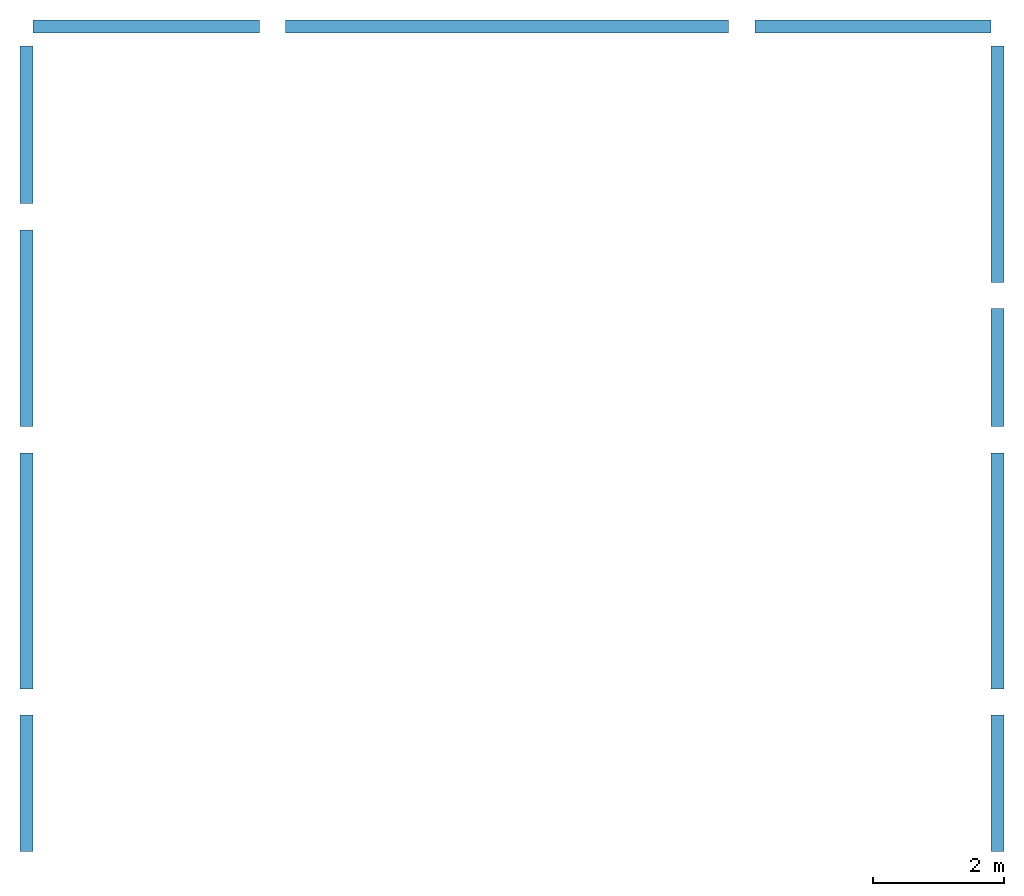
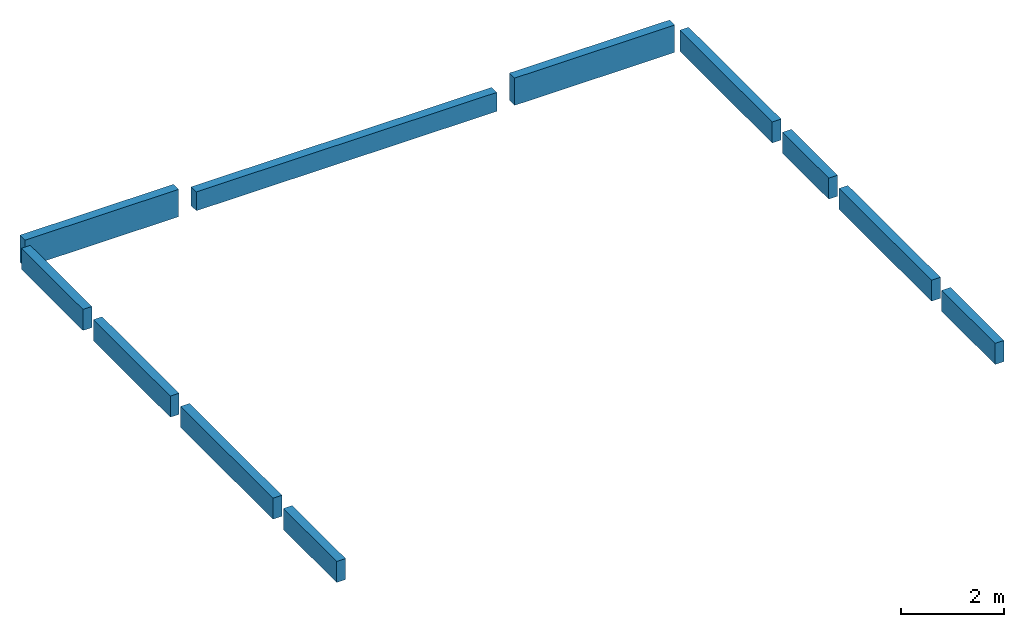
# One storey: 11 walls.
"""IFC4 building model written with IfcOpenShell, lengths in metres."""

from ifc_helpers import new_model, entity, si_unit, converted_unit, frame, origin_with_axes, origin_2d_with_axis, place, context, subcontext, project, spatial, indexed_curve, outline, extrude, material, layer, layer_set, layer_usage, type_object, element, save


model = new_model("IFC4")

# Units and contexts
model_context = context("Model", 3, precision=1e-05, world=origin_with_axes())
plan_context = context("Plan", 2, precision=1e-05, world=origin_2d_with_axis())
body_context = subcontext(model_context, "Body", "Model", "MODEL_VIEW")
ifc_project = project(units=[si_unit("VOLUMEUNIT", "CUBIC_METRE"), si_unit("LENGTHUNIT", "METRE"), converted_unit("PLANEANGLEUNIT", "degree", entity("IfcReal", 0.0174532925199433), si_unit("PLANEANGLEUNIT", "RADIAN"), dimensions=[0, 0, 0, 0, 0, 0, 0]), si_unit("AREAUNIT", "SQUARE_METRE")], contexts=[model_context, plan_context])

# Site, building, storey
site_placement = place(None, origin_with_axes())
site = spatial("IfcSite", under=ifc_project, at=site_placement)
building_placement = place(site_placement, origin_with_axes())
building = spatial("IfcBuilding", under=site, at=building_placement, Name="Building")
storey_placement = place(building_placement, frame((0.0, 0.0, 3.65000009536743), z_axis=(0.0, 0.0, 1.0), x_axis=(1.0, 0.0, 0.0)))
storey = spatial("IfcBuildingStorey", under=building, at=storey_placement, Name="2-Roof1")

# Walls
ifc_material = material(Name="BLK-200", Category="masonry")
ifc_layer = layer(ifc_material, 0.200000002980232)
ifc_layer_set = layer_set([ifc_layer])
ifc_layer_usage_1 = layer_usage(ifc_layer_set, "AXIS2", "POSITIVE", 0.0)
wall_type = type_object("IfcWallType", Name="WAL-01", PredefinedType="STANDARD", material=ifc_layer_set)
wall_1_placement = place(storey_placement, frame((39.5796699523926, 24.8144187927246, -0.150000572204592), z_axis=(0.0, 0.0, 1.0), x_axis=(-0.999999999999989, 1.50995802528085e-07, 0.0)))
element("IfcWall", 1, at=wall_1_placement, inside=storey, type_object=wall_type, material=ifc_layer_usage_1, Name="Wall", context=body_context, shape_type="SweptSolid", body=[
    extrude(outline(indexed_curve([(0.0, 0.0), (0.0, 0.200000002980232), (3.44997030604756, 0.200000002980232), (3.44997030604756, 0.0), (0.0, 0.0)], self_intersect=False)), origin_with_axes(), (0.0, 0.0, 1.0), 0.649999976158142),
])
ifc_layer_usage_2 = layer_usage(ifc_layer_set, "AXIS2", "POSITIVE", 0.0)
wall_2_placement = place(storey_placement, frame((50.7346954345703, 24.8144187927246, -0.149999856948852), z_axis=(0.0, 0.0, 1.0), x_axis=(-0.999999999999989, 1.50995802528085e-07, 0.0)))
element("IfcWall", 2, at=wall_2_placement, inside=storey, type_object=wall_type, material=ifc_layer_usage_2, Name="Wall", context=body_context, shape_type="SweptSolid", body=[
    extrude(outline(indexed_curve([(0.0, 0.0), (0.0, 0.200000002980232), (3.59999470710365, 0.200000002980232), (3.59999470710365, 0.0), (0.0, 0.0)], self_intersect=False)), origin_with_axes(), (0.0, 0.0, 1.0), 0.649999976158142),
])
ifc_layer_usage_3 = layer_usage(ifc_layer_set, "AXIS2", "POSITIVE", 0.0)
wall_3_placement = place(storey_placement, frame((46.7346992492676, 24.8144187927246, -0.150000095367432), z_axis=(0.0, 0.0, 1.0), x_axis=(-0.999999999999989, 1.50995802528085e-07, 0.0)))
element("IfcWall", 3, at=wall_3_placement, inside=storey, type_object=wall_type, material=ifc_layer_usage_3, Name="Wall", context=body_context, shape_type="SweptSolid", body=[
    extrude(outline(indexed_curve([(0.0, 0.0), (0.0, 0.200000002980232), (6.75502787642892, 0.200000002980232), (6.75502787642892, 0.0), (0.0, 0.0)], self_intersect=False)), origin_with_axes(), (0.0, 0.0, 1.0), 0.449999988079071),
])
ifc_layer_usage_4 = layer_usage(ifc_layer_set, "AXIS2", "POSITIVE", 0.0)
wall_4_placement = place(storey_placement, frame((50.7346954345703, 24.4144134521484, -2.38418581766098e-07), z_axis=(0.0, 0.0, 1.0), x_axis=(-5.2054855359522e-07, -0.999999999999865, 0.0)))
element("IfcWall", 4, at=wall_4_placement, inside=storey, type_object=wall_type, material=ifc_layer_usage_4, Name="Wall", context=body_context, shape_type="SweptSolid", body=[
    extrude(outline(indexed_curve([(0.0, 0.0), (0.0, 0.200000002980232), (3.59988397305327, 0.200000002980232), (3.59988397305327, 0.0), (0.0, 0.0)], self_intersect=False)), origin_with_axes(), (0.0, 0.0, 1.0), 0.5),
])
ifc_layer_usage_5 = layer_usage(ifc_layer_set, "AXIS2", "POSITIVE", 0.0)
wall_5_placement = place(storey_placement, frame((50.7346954345703, 18.2143020629883, -2.38418581766098e-07), z_axis=(0.0, 0.0, 1.0), x_axis=(-5.2054855359522e-07, -0.999999999999865, 0.0)))
element("IfcWall", 5, at=wall_5_placement, inside=storey, type_object=wall_type, material=ifc_layer_usage_5, Name="Wall", context=body_context, shape_type="SweptSolid", body=[
    extrude(outline(indexed_curve([(0.0, 0.0), (0.0, 0.200000002980232), (3.59988397305327, 0.200000002980232), (3.59988397305327, 0.0), (0.0, 0.0)], self_intersect=False)), origin_with_axes(), (0.0, 0.0, 1.0), 0.5),
])
ifc_layer_usage_6 = layer_usage(ifc_layer_set, "AXIS2", "POSITIVE", 0.0)
wall_6_placement = place(storey_placement, frame((50.7346954345703, 20.414529800415, -2.38418581766098e-07), z_axis=(0.0, 0.0, 1.0), x_axis=(-5.2054855359522e-07, -0.999999999999865, 0.0)))
element("IfcWall", 6, at=wall_6_placement, inside=storey, type_object=wall_type, material=ifc_layer_usage_6, Name="Wall", context=body_context, shape_type="SweptSolid", body=[
    extrude(outline(indexed_curve([(0.0, 0.0), (0.0, 0.200000002980232), (1.80011179100029, 0.200000002980232), (1.80011179100029, 0.0), (0.0, 0.0)], self_intersect=False)), origin_with_axes(), (0.0, 0.0, 1.0), 0.5),
])
ifc_layer_usage_7 = layer_usage(ifc_layer_set, "AXIS2", "POSITIVE", 0.0)
wall_7_placement = place(storey_placement, frame((50.7346954345703, 14.2144165039062, -2.38418581766098e-07), z_axis=(0.0, 0.0, 1.0), x_axis=(-5.2054855359522e-07, -0.999999999999865, 0.0)))
element("IfcWall", 7, at=wall_7_placement, inside=storey, type_object=wall_type, material=ifc_layer_usage_7, Name="Wall", context=body_context, shape_type="SweptSolid", body=[
    extrude(outline(indexed_curve([(0.0, 0.0), (0.0, 0.200000002980232), (2.07987214264008, 0.200000002980232), (2.07987214264008, 0.0), (0.0, 0.0)], self_intersect=False)), origin_with_axes(), (0.0, 0.0, 1.0), 0.5),
])
ifc_layer_usage_8 = layer_usage(ifc_layer_set, "AXIS2", "POSITIVE", 0.0)
wall_8_placement = place(storey_placement, frame((35.9296989440918, 14.2144165039062, -2.38418581766098e-07), z_axis=(0.0, 0.0, 1.0), x_axis=(-5.2054855359522e-07, -0.999999999999865, 0.0)))
element("IfcWall", 8, at=wall_8_placement, inside=storey, type_object=wall_type, material=ifc_layer_usage_8, Name="Wall", context=body_context, shape_type="SweptSolid", body=[
    extrude(outline(indexed_curve([(0.0, 0.0), (0.0, 0.200000002980232), (2.07987214264008, 0.200000002980232), (2.07987214264008, 0.0), (0.0, 0.0)], self_intersect=False)), origin_with_axes(), (0.0, 0.0, 1.0), 0.5),
])
ifc_layer_usage_9 = layer_usage(ifc_layer_set, "AXIS2", "POSITIVE", 0.0)
wall_9_placement = place(storey_placement, frame((35.9296989440918, 18.2144165039062, -2.38418581766098e-07), z_axis=(0.0, 0.0, 1.0), x_axis=(-5.2054855359522e-07, -0.999999999999865, 0.0)))
element("IfcWall", 9, at=wall_9_placement, inside=storey, type_object=wall_type, material=ifc_layer_usage_9, Name="Wall", context=body_context, shape_type="SweptSolid", body=[
    extrude(outline(indexed_curve([(0.0, 0.0), (0.0, 0.200000002980232), (3.59999947547909, 0.200000002980232), (3.59999947547909, 0.0), (0.0, 0.0)], self_intersect=False)), origin_with_axes(), (0.0, 0.0, 1.0), 0.5),
])
ifc_layer_usage_10 = layer_usage(ifc_layer_set, "AXIS2", "POSITIVE", 0.0)
wall_10_placement = place(storey_placement, frame((35.9296989440918, 21.6144161224365, -2.38418581766098e-07), z_axis=(0.0, 0.0, 1.0), x_axis=(-5.2054855359522e-07, -0.999999999999865, 0.0)))
element("IfcWall", 10, at=wall_10_placement, inside=storey, type_object=wall_type, material=ifc_layer_usage_10, Name="Wall", context=body_context, shape_type="SweptSolid", body=[
    extrude(outline(indexed_curve([(0.0, 0.0), (0.0, 0.200000002980232), (2.99999809265076, 0.200000002980232), (2.99999809265076, 0.0), (0.0, 0.0)], self_intersect=False)), origin_with_axes(), (0.0, 0.0, 1.0), 0.5),
])
ifc_layer_usage_11 = layer_usage(ifc_layer_set, "AXIS2", "POSITIVE", 0.0)
wall_11_placement = place(storey_placement, frame((35.9296989440918, 24.4144191741943, -2.38418581766098e-07), z_axis=(0.0, 0.0, 1.0), x_axis=(-5.2054855359522e-07, -0.999999999999865, 0.0)))
element("IfcWall", 11, at=wall_11_placement, inside=storey, type_object=wall_type, material=ifc_layer_usage_11, Name="Wall", context=body_context, shape_type="SweptSolid", body=[
    extrude(outline(indexed_curve([(0.0, 0.0), (0.0, 0.200000002980232), (2.40000342527781, 0.200000002980232), (2.40000342527781, 0.0), (0.0, 0.0)], self_intersect=False)), origin_with_axes(), (0.0, 0.0, 1.0), 0.5),
])

save(model, "model.ifc")
